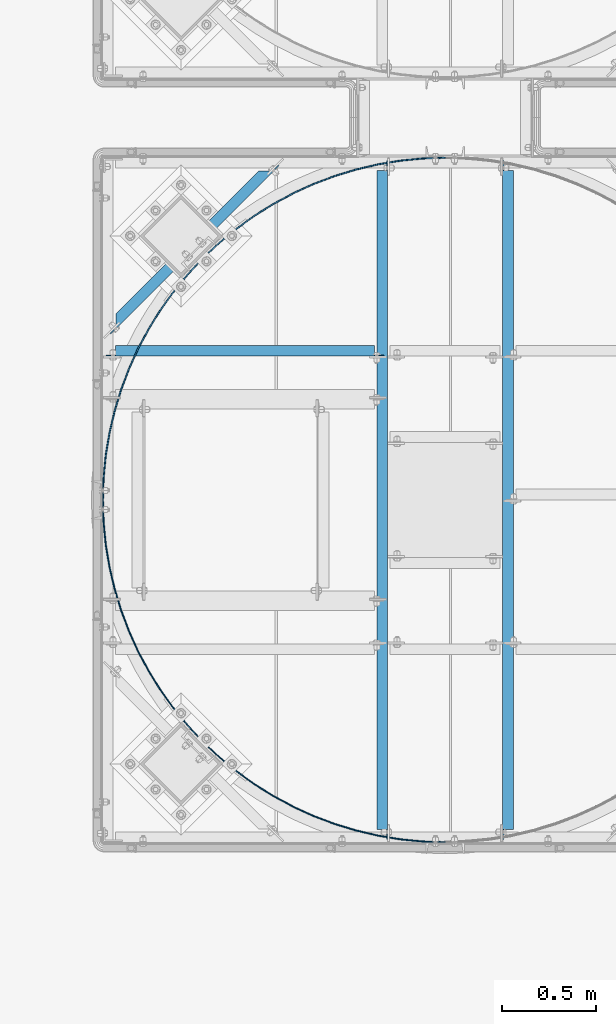
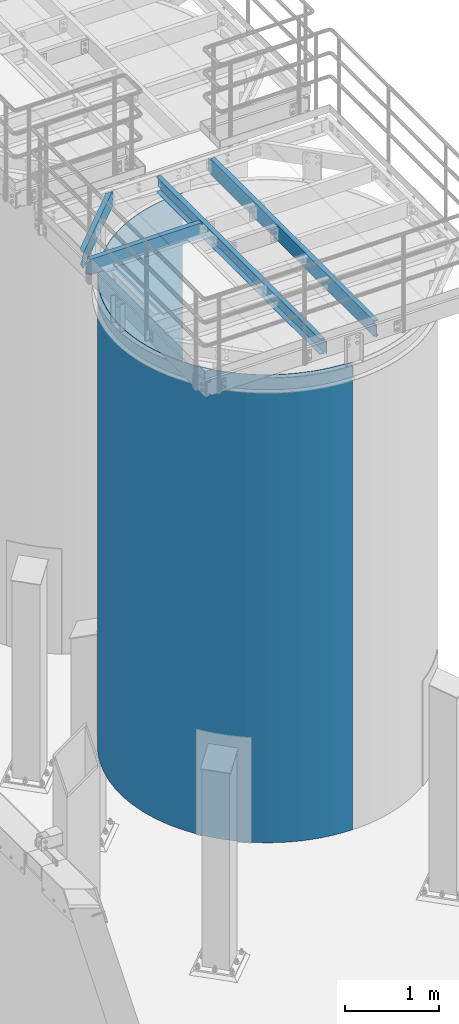
# One storey, part 921 of 1876: 5 beams, 5 elements without a shape of their own.
"""IFC2X3 building model written with IfcOpenShell, lengths in millimetres."""

from ifc_helpers import new_model, si_unit, frame, origin_with_axes, place, context, subcontext, project, spatial, faceted_brep, material, type_object, element, aggregate, save


model = new_model("IFC2X3")

# Units and contexts
model_context = context("Model", 3, precision=1e-05, world=origin_with_axes())
body_context = subcontext(model_context, "Body", "Model", "MODEL_VIEW")
ifc_project = project(units=[si_unit("LENGTHUNIT", "METRE", prefix="MILLI"), si_unit("AREAUNIT", "SQUARE_METRE"), si_unit("VOLUMEUNIT", "CUBIC_METRE"), si_unit("MASSUNIT", "GRAM", prefix="KILO"), si_unit("TIMEUNIT", "SECOND"), si_unit("PLANEANGLEUNIT", "RADIAN"), si_unit("SOLIDANGLEUNIT", "STERADIAN"), si_unit("THERMODYNAMICTEMPERATUREUNIT", "DEGREE_CELSIUS"), si_unit("LUMINOUSINTENSITYUNIT", "LUMEN")], contexts=[model_context])

# Site, building, storey
site_placement = place(None, origin_with_axes())
site = spatial("IfcSite", under=ifc_project, at=site_placement, CompositionType="ELEMENT")
building_placement = place(site_placement, origin_with_axes())
building = spatial("IfcBuilding", under=site, at=building_placement, Name="Undefined", CompositionType="ELEMENT")
storey_placement = place(building_placement, origin_with_axes())
storey = spatial("IfcBuildingStorey", under=building, at=storey_placement, Name="Undefined", CompositionType="ELEMENT", Elevation=0.0)

# Assembly, beam
assembly_1_placement = place(storey_placement, origin_with_axes())
assembly_1 = element("IfcElementAssembly", 1, at=assembly_1_placement, inside=storey, Name="BEAM", AssemblyPlace="NOTDEFINED", PredefinedType="RIGID_FRAME")
ifc_material = material(Name="STEEL/A36")
beam_type_1 = type_object("IfcBeamType", Name="C8X11.5", PredefinedType="NOTDEFINED")
beam_1_placement = place(assembly_1_placement, frame((3349.4630422288, -12731.5510638513, 7896.225), z_axis=(0.0, 0.0, -1.0), x_axis=(0.707106781186548, 0.707106781186547, 0.0)))
beam_1 = element("IfcBeam", 2, at=beam_1_placement, type_object=beam_type_1, material=ifc_material, Name="BEAM", ObjectType="C8X11.5", context=body_context, shape_type="Brep", body=[
    faceted_brep([(154.529650862243, -28.5750000000025, 101.6), (154.529650862243, -28.5750000000025, 96.8355949999996), (1223.93966372519, -28.5750000000044, 96.8355949999996), (1223.93966372519, -28.5750000000044, 101.6), (1281.0896637252, 28.5750000000053, 101.6), (1271.57228791927, 19.0576241940789, 88.8999998092668), (1281.0896637252, 28.5750000000053, 88.8999998092668), (97.3796508622331, 28.5750000000062, 101.6), (1299.05017569896, 28.5750000000053, -76.1999999999971), (1292.70017569896, 22.225000000004, -76.1999999999971), (1285.82698533033, 22.2250000000049, -77.1667299225846), (1292.17698533033, 28.5750000000062, -77.1667299225846), (1280.00017588969, 22.2250000000049, -79.9197438230631), (1286.35017588969, 28.5750000000062, -79.9197438230631), (1276.10682629423, 22.2250000000031, -84.0399202912167), (1282.45682629424, 28.5750000000044, -84.0399202912167), (1281.08966372656, 28.5750000000062, -88.8999998092622), (1271.57228792066, 19.0576241941089, -88.8999998092622), (1223.93966372655, -28.5750000000035, -96.8355949999996), (1223.93966372655, -28.5750000000035, -101.6), (1281.08966372656, 28.5750000000062, -101.6), (1274.88810387369, 22.225000000004, -88.3723149999996), (103.581210715046, 22.225000000004, -88.3723149999996), (106.897026668097, 19.0576241940926, -88.899999809265), (154.529650862193, -28.5750000000044, -96.8355949999996), (154.529650862193, -28.5750000000044, -101.6), (97.3796508621845, 28.5750000000044, -101.6), (97.3796508621845, 28.5750000000044, -88.899999809265), (102.362488294509, 22.225000000004, -84.0399202912195), (96.0124882945074, 28.5750000000062, -84.0399202912195), (98.4691386990489, 22.2250000000058, -79.9197438230658), (92.1191386990495, 28.5750000000044, -79.9197438230658), (92.6423292584141, 22.225000000004, -77.1667299225874), (86.2923292584137, 28.5750000000044, -77.1667299225874), (85.7691388897797, 22.225000000004, -76.1999999999998), (79.4191388897784, 28.5750000000062, -76.1999999999998), (59.1474759898592, 22.225000000004, -76.1999999999998), (59.1474759898588, 28.5750000000062, -76.1999999999998), (59.1474759898592, 22.225000000004, 76.1999999999998), (59.1474759898588, 28.5750000000062, 76.1999999999998), (85.7691388898302, 22.225000000004, 76.1999999999998), (79.4191388898289, 28.5750000000062, 76.1999999999998), (92.6423292584636, 22.225000000004, 77.1667299225874), (86.2923292584624, 28.5750000000062, 77.1667299225874), (98.4691386990994, 22.225000000004, 79.9197438230658), (92.119138699099, 28.5750000000062, 79.9197438230658), (102.362488294559, 22.225000000004, 84.0399202912195), (96.0124882945579, 28.5750000000062, 84.0399202912195), (106.897026668147, 19.0576241940926, 88.899999809265), (97.3796508622331, 28.5750000000062, 88.899999809265), (103.581210715098, 22.225000000004, 88.3723149999996), (1274.88810387234, 22.2250000000049, 88.3723149999996), (1276.10682629288, 22.225000000004, 84.0399202912213), (1282.45682629288, 28.5750000000044, 84.0399202912213), (1280.00017588834, 22.225000000004, 79.9197438230676), (1286.35017588834, 28.5750000000053, 79.9197438230676), (1285.82698532897, 22.225000000004, 77.1667299225892), (1292.17698532897, 28.5750000000053, 77.1667299225892), (1292.7001756976, 22.2250000000049, 76.2000000000016), (1299.0501756976, 28.5750000000053, 76.2000000000016), (1319.3218385947, 22.225000000004, 76.2000000000016), (1319.3218385947, 28.5750000000053, 76.2000000000016), (1319.3218385947, 28.5750000000053, -76.1999999999971), (1319.3218385947, 22.225000000004, -76.1999999999971)], [[[0, 1, 2, 3]], [[4, 3, 2, 5, 6]], [[7, 0, 3, 4]], [[8, 9, 10, 11]], [[11, 10, 12, 13]], [[13, 12, 14, 15]], [[16, 17, 18, 19, 20]], [[15, 14, 21, 17, 16]], [[22, 23, 24, 18, 17, 21]], [[24, 25, 19, 18]], [[25, 26, 20, 19]], [[24, 23, 27, 26, 25]], [[22, 28, 29, 27, 23]], [[30, 31, 29, 28]], [[32, 33, 31, 30]], [[34, 35, 33, 32]], [[35, 34, 36, 37]], [[37, 36, 38, 39]], [[40, 41, 39, 38]], [[42, 43, 41, 40]], [[44, 45, 43, 42]], [[46, 47, 45, 44]], [[48, 49, 47, 46, 50]], [[0, 7, 49, 48, 1]], [[2, 1, 48, 50, 51, 5]], [[6, 5, 51, 52, 53]], [[53, 52, 54, 55]], [[55, 54, 56, 57]], [[57, 56, 58, 59]], [[59, 58, 60, 61]], [[41, 43, 45, 47, 49, 7, 4, 6, 53, 55, 57, 59, 61, 62, 8, 11, 13, 15, 16, 20, 26, 27, 29, 31, 33, 35, 37, 39]], [[9, 8, 62, 63]], [[34, 32, 30, 28, 22, 21, 14, 12, 10, 9, 63, 60, 58, 56, 54, 52, 51, 50, 46, 44, 42, 40, 38, 36]], [[62, 61, 60, 63]]]),
])
aggregate(assembly_1, [beam_1])

assembly_2_placement = place(storey_placement, origin_with_axes())
assembly_2 = element("IfcElementAssembly", 3, at=assembly_2_placement, inside=storey, Name="BEAM", AssemblyPlace="NOTDEFINED", PredefinedType="RIGID_FRAME")
beam_2_placement = place(assembly_2_placement, frame((3365.50143150122, -12798.3894042969, 7896.225), z_axis=(0.0, 0.0, -1.0), x_axis=(1.0, 0.0, 0.0)))
beam_2 = element("IfcBeam", 4, at=beam_2_placement, type_object=beam_type_1, material=ifc_material, Name="BEAM", ObjectType="C8X11.5", context=body_context, shape_type="Brep", body=[
    faceted_brep([(19.0499999999993, 22.2250000000004, -76.2000000000007), (19.0499999999993, 28.5750000000007, -76.2000000000007), (57.1500001907361, 28.5750000000007, -76.2000000000007), (57.1500001907361, 22.2250000000004, -76.2000000000007), (62.0100797087816, 28.5750000000007, -77.1667299225883), (62.0100797087816, 22.2250000000004, -77.1667299225883), (66.1302561769353, 28.5750000000007, -79.9197438230667), (66.1302561769353, 22.2250000000004, -79.9197438230667), (68.8832700774137, 28.5750000000007, -84.0399202912204), (68.8832700774137, 22.2250000000004, -84.0399202912204), (69.8500000000013, 19.0576241940817, -88.8999998092659), (69.8500000000013, 28.5750000000007, -88.8999998092659), (69.8500000000013, 28.5750000000007, -101.6), (69.8500000000013, -28.5750000000007, -101.6), (69.8500000000013, -28.5750000000007, -96.8355949999996), (69.7450369653598, 22.2250000000004, -88.3723149999996), (1441.45, -28.5750000000007, -96.8355949999996), (1441.45, -28.5750000000007, -101.6), (1441.45, 28.5750000000007, -101.6), (1441.45, 28.5750000000007, -88.899999809264), (1441.45, 19.0576241940926, -88.899999809264), (69.8500000000013, -28.5750000000007, 101.6), (69.8500000000013, -28.5750000000007, 96.8355949999996), (1441.45, -28.5750000000007, 96.8355949999996), (1441.45, -28.5750000000007, 101.6), (1441.45, 19.0576241940817, 88.8999998092659), (1441.45, 28.5750000000007, 88.8999998092659), (1441.45, 28.5750000000007, 101.6), (69.8500000000013, 28.5750000000007, 101.6), (57.1500001907361, 22.2250000000004, 76.1999999999989), (57.1500001907361, 28.5750000000007, 76.1999999999989), (19.0499999999993, 28.5750000000007, 76.1999999999989), (19.0499999999993, 22.2250000000004, 76.1999999999989), (62.0100797087816, 22.2250000000004, 77.1667299225865), (62.0100797087816, 28.5750000000007, 77.1667299225865), (66.1302561769353, 22.2250000000004, 79.9197438230649), (66.1302561769353, 28.5750000000007, 79.9197438230649), (68.8832700774137, 22.2250000000004, 84.0399202912186), (68.8832700774137, 28.5750000000007, 84.0399202912186), (69.8500000000013, 19.0576241940926, 88.899999809264), (69.8500000000013, 28.5750000000007, 88.899999809264), (69.7450369653607, 22.2250000000004, 88.3723149999996), (1441.55496303464, 22.2250000000004, 88.3723149999996), (1442.41672992259, 22.2250000000004, 84.0399202912204), (1442.41672992259, 28.5750000000007, 84.0399202912204), (1445.16974382306, 22.2250000000004, 79.9197438230667), (1445.16974382306, 28.5750000000007, 79.9197438230667), (1449.28992029122, 22.2250000000004, 77.1667299225883), (1449.28992029122, 28.5750000000007, 77.1667299225883), (1454.14999980926, 22.2250000000004, 76.2000000000007), (1454.14999980926, 28.5750000000007, 76.2000000000007), (1492.25, 22.2250000000004, 76.2000000000007), (1492.25, 28.5750000000007, 76.2000000000007), (1492.25, 22.2250000000004, -76.1999999999989), (1492.25, 28.5750000000007, -76.1999999999989), (1454.14999980926, 22.2250000000004, -76.1999999999989), (1454.14999980926, 28.5750000000007, -76.1999999999989), (1449.28992029122, 22.2250000000004, -77.1667299225865), (1449.28992029122, 28.5750000000007, -77.1667299225865), (1445.16974382306, 22.2250000000004, -79.9197438230649), (1445.16974382306, 28.5750000000007, -79.9197438230649), (1442.41672992259, 22.2250000000004, -84.0399202912186), (1442.41672992259, 28.5750000000007, -84.0399202912186), (1441.55496303464, 22.2250000000004, -88.3723149999996)], [[[0, 1, 2, 3]], [[3, 2, 4, 5]], [[5, 4, 6, 7]], [[7, 6, 8, 9]], [[10, 11, 12, 13, 14]], [[15, 9, 8, 11, 10]], [[16, 17, 18, 19, 20]], [[21, 22, 23, 24]], [[24, 23, 25, 26, 27]], [[28, 21, 24, 27]], [[29, 30, 31, 32]], [[33, 34, 30, 29]], [[35, 36, 34, 33]], [[37, 38, 36, 35]], [[39, 40, 38, 37, 41]], [[21, 28, 40, 39, 22]], [[22, 39, 41, 42, 25, 23]], [[43, 44, 26, 25, 42]], [[45, 46, 44, 43]], [[47, 48, 46, 45]], [[49, 50, 48, 47]], [[51, 52, 50, 49]], [[52, 51, 53, 54]], [[53, 55, 56, 54]], [[57, 58, 56, 55]], [[59, 60, 58, 57]], [[61, 62, 60, 59]], [[63, 20, 19, 62, 61]], [[15, 10, 14, 16, 20, 63]], [[14, 13, 17, 16]], [[13, 12, 18, 17]], [[58, 60, 62, 19, 18, 12, 11, 8, 6, 4, 2, 1, 31, 30, 34, 36, 38, 40, 28, 27, 26, 44, 46, 48, 50, 52, 54, 56]], [[32, 31, 1, 0]], [[51, 49, 47, 45, 43, 42, 41, 37, 35, 33, 29, 32, 0, 3, 5, 7, 9, 15, 63, 61, 59, 57, 55, 53]]]),
])
aggregate(assembly_2, [beam_2])

assembly_3_placement = place(storey_placement, origin_with_axes())
assembly_3 = element("IfcElementAssembly", 5, at=assembly_3_placement, inside=storey, Name="BEAM", AssemblyPlace="NOTDEFINED", PredefinedType="RIGID_FRAME")
beam_3_placement = place(assembly_3_placement, frame((5514.97643150122, -15405.0644042969, 7896.225), z_axis=(0.0, 0.0, 1.0), x_axis=(0.0, 1.0, 0.0)))
beam_3 = element("IfcBeam", 6, at=beam_3_placement, type_object=beam_type_1, material=ifc_material, Name="BEAM", ObjectType="C8X11.5", context=body_context, shape_type="Brep", body=[
    faceted_brep([(19.0499999999993, 22.2250000000004, -76.2000000000007), (19.0499999999993, 28.5750000000007, -76.2000000000007), (57.1500001907361, 28.5750000000007, -76.2000000000007), (57.1500001907361, 22.2250000000004, -76.2000000000007), (62.0100797087816, 28.5750000000007, -77.1667299225883), (62.0100797087816, 22.2250000000004, -77.1667299225883), (66.1302561769353, 28.5750000000007, -79.9197438230667), (66.1302561769353, 22.2250000000004, -79.9197438230667), (68.8832700774137, 28.5750000000007, -84.0399202912204), (68.8832700774137, 22.2250000000004, -84.0399202912204), (69.8500000000013, 19.0576241940817, -88.8999998092659), (69.8500000000013, 28.5750000000007, -88.8999998092659), (69.8500000000013, 28.5750000000007, -101.6), (69.8500000000013, -28.5750000000007, -101.6), (69.8500000000013, -28.5750000000007, -96.8355949999996), (69.7450369653598, 22.2250000000004, -88.3723149999996), (3562.3499511731, -28.5749999999998, -96.8355949999996), (3562.3499511731, -28.5749999999998, -101.6), (3562.3499511731, 28.5749999999998, -101.6), (3562.3499511731, 28.5749999999998, -88.899999809264), (3562.3499511731, 19.0576241940935, -88.899999809264), (69.8500000000013, -28.5750000000007, 101.6), (69.8500000000013, -28.5750000000007, 96.8355949999996), (3562.3499511731, -28.5749999999998, 96.8355949999996), (3562.3499511731, -28.5749999999998, 101.6), (3562.3499511731, 19.0576241940826, 88.8999998092659), (3562.3499511731, 28.5749999999998, 88.8999998092659), (3562.3499511731, 28.5749999999998, 101.6), (69.8500000000013, 28.5750000000007, 101.6), (57.1500001907361, 22.2250000000004, 76.1999999999989), (57.1500001907361, 28.5750000000007, 76.1999999999989), (19.0499999999993, 28.5750000000007, 76.1999999999989), (19.0499999999993, 22.2250000000004, 76.1999999999989), (62.0100797087816, 22.2250000000004, 77.1667299225865), (62.0100797087816, 28.5750000000007, 77.1667299225865), (66.1302561769353, 22.2250000000004, 79.9197438230649), (66.1302561769353, 28.5750000000007, 79.9197438230649), (68.8832700774137, 22.2250000000004, 84.0399202912186), (68.8832700774137, 28.5750000000007, 84.0399202912186), (69.8500000000013, 19.0576241940926, 88.899999809264), (69.8500000000013, 28.5750000000007, 88.899999809264), (69.7450369653607, 22.2250000000004, 88.3723149999996), (3562.45491420775, 22.2250000000004, 88.3723149999996), (3563.31668109569, 22.2250000000004, 84.0399202912204), (3563.31668109569, 28.5749999999998, 84.0399202912204), (3566.06969499617, 22.2250000000004, 79.9197438230667), (3566.06969499617, 28.5749999999998, 79.9197438230667), (3570.18987146432, 22.2250000000004, 77.1667299225883), (3570.18987146432, 28.5749999999998, 77.1667299225883), (3575.04995098237, 22.2250000000004, 76.2000000000007), (3575.04995098237, 28.5749999999998, 76.2000000000007), (3613.1499511731, 22.2250000000004, 76.2000000000007), (3613.1499511731, 28.5749999999998, 76.2000000000007), (3613.1499511731, 22.2250000000004, -76.1999999999989), (3613.1499511731, 28.5749999999998, -76.1999999999989), (3575.04995098237, 22.2250000000004, -76.1999999999989), (3575.04995098237, 28.5749999999998, -76.1999999999989), (3570.18987146432, 22.2250000000004, -77.1667299225865), (3570.18987146432, 28.5749999999998, -77.1667299225865), (3566.06969499617, 22.2250000000004, -79.9197438230649), (3566.06969499617, 28.5749999999998, -79.9197438230649), (3563.31668109569, 22.2250000000004, -84.0399202912186), (3563.31668109569, 28.5749999999998, -84.0399202912186), (3562.45491420774, 22.2250000000004, -88.3723149999996)], [[[0, 1, 2, 3]], [[3, 2, 4, 5]], [[5, 4, 6, 7]], [[7, 6, 8, 9]], [[10, 11, 12, 13, 14]], [[15, 9, 8, 11, 10]], [[16, 17, 18, 19, 20]], [[21, 22, 23, 24]], [[24, 23, 25, 26, 27]], [[28, 21, 24, 27]], [[29, 30, 31, 32]], [[33, 34, 30, 29]], [[35, 36, 34, 33]], [[37, 38, 36, 35]], [[39, 40, 38, 37, 41]], [[21, 28, 40, 39, 22]], [[22, 39, 41, 42, 25, 23]], [[43, 44, 26, 25, 42]], [[45, 46, 44, 43]], [[47, 48, 46, 45]], [[49, 50, 48, 47]], [[51, 52, 50, 49]], [[52, 51, 53, 54]], [[53, 55, 56, 54]], [[57, 58, 56, 55]], [[59, 60, 58, 57]], [[61, 62, 60, 59]], [[63, 20, 19, 62, 61]], [[15, 10, 14, 16, 20, 63]], [[14, 13, 17, 16]], [[13, 12, 18, 17]], [[58, 60, 62, 19, 18, 12, 11, 8, 6, 4, 2, 1, 31, 30, 34, 36, 38, 40, 28, 27, 26, 44, 46, 48, 50, 52, 54, 56]], [[32, 31, 1, 0]], [[51, 49, 47, 45, 43, 42, 41, 37, 35, 33, 29, 32, 0, 3, 5, 7, 9, 15, 63, 61, 59, 57, 55, 53]]]),
])
aggregate(assembly_3, [beam_3])

assembly_4_placement = place(storey_placement, origin_with_axes())
assembly_4 = element("IfcElementAssembly", 7, at=assembly_4_placement, inside=storey, Name="BEAM", AssemblyPlace="NOTDEFINED", PredefinedType="RIGID_FRAME")
beam_4_placement = place(assembly_4_placement, frame((4848.22643150122, -15405.0644042969, 7896.225), z_axis=(0.0, 0.0, -1.0), x_axis=(0.0, 1.0, 0.0)))
beam_4 = element("IfcBeam", 8, at=beam_4_placement, type_object=beam_type_1, material=ifc_material, Name="BEAM", ObjectType="C8X11.5", context=body_context, shape_type="Brep", body=[
    faceted_brep([(19.0499999999993, 22.2250000000004, -76.2000000000007), (19.0499999999993, 28.5750000000007, -76.2000000000007), (57.1500001907361, 28.5750000000007, -76.2000000000007), (57.1500001907361, 22.2250000000004, -76.2000000000007), (62.0100797087816, 28.5750000000007, -77.1667299225883), (62.0100797087816, 22.2250000000004, -77.1667299225883), (66.1302561769353, 28.5750000000007, -79.9197438230667), (66.1302561769353, 22.2250000000004, -79.9197438230667), (68.8832700774137, 28.5750000000007, -84.0399202912204), (68.8832700774137, 22.2250000000004, -84.0399202912204), (69.8500000000013, 19.0576241940817, -88.8999998092659), (69.8500000000013, 28.5750000000007, -88.8999998092659), (69.8500000000013, 28.5750000000007, -101.6), (69.8500000000013, -28.5750000000007, -101.6), (69.8500000000013, -28.5750000000007, -96.8355949999996), (69.7450369653598, 22.2250000000004, -88.3723149999996), (3562.3499511731, -28.5749999999998, -96.8355949999996), (3562.3499511731, -28.5749999999998, -101.6), (3562.3499511731, 28.5749999999998, -101.6), (3562.3499511731, 28.5749999999998, -88.899999809264), (3562.3499511731, 19.0576241940935, -88.899999809264), (69.8500000000013, -28.5750000000007, 101.6), (69.8500000000013, -28.5750000000007, 96.8355949999996), (3562.3499511731, -28.5749999999998, 96.8355949999996), (3562.3499511731, -28.5749999999998, 101.6), (3562.3499511731, 19.0576241940826, 88.8999998092659), (3562.3499511731, 28.5749999999998, 88.8999998092659), (3562.3499511731, 28.5749999999998, 101.6), (69.8500000000013, 28.5750000000007, 101.6), (57.1500001907361, 22.2250000000004, 76.1999999999989), (57.1500001907361, 28.5750000000007, 76.1999999999989), (19.0499999999993, 28.5750000000007, 76.1999999999989), (19.0499999999993, 22.2250000000004, 76.1999999999989), (62.0100797087816, 22.2250000000004, 77.1667299225865), (62.0100797087816, 28.5750000000007, 77.1667299225865), (66.1302561769353, 22.2250000000004, 79.9197438230649), (66.1302561769353, 28.5750000000007, 79.9197438230649), (68.8832700774137, 22.2250000000004, 84.0399202912186), (68.8832700774137, 28.5750000000007, 84.0399202912186), (69.8500000000013, 19.0576241940926, 88.899999809264), (69.8500000000013, 28.5750000000007, 88.899999809264), (69.7450369653607, 22.2250000000004, 88.3723149999996), (3562.45491420775, 22.2250000000004, 88.3723149999996), (3563.31668109569, 22.2250000000004, 84.0399202912204), (3563.31668109569, 28.5749999999998, 84.0399202912204), (3566.06969499617, 22.2250000000004, 79.9197438230667), (3566.06969499617, 28.5749999999998, 79.9197438230667), (3570.18987146432, 22.2250000000004, 77.1667299225883), (3570.18987146432, 28.5749999999998, 77.1667299225883), (3575.04995098237, 22.2250000000004, 76.2000000000007), (3575.04995098237, 28.5749999999998, 76.2000000000007), (3613.1499511731, 22.2250000000004, 76.2000000000007), (3613.1499511731, 28.5749999999998, 76.2000000000007), (3613.1499511731, 22.2250000000004, -76.1999999999989), (3613.1499511731, 28.5749999999998, -76.1999999999989), (3575.04995098237, 22.2250000000004, -76.1999999999989), (3575.04995098237, 28.5749999999998, -76.1999999999989), (3570.18987146432, 22.2250000000004, -77.1667299225865), (3570.18987146432, 28.5749999999998, -77.1667299225865), (3566.06969499617, 22.2250000000004, -79.9197438230649), (3566.06969499617, 28.5749999999998, -79.9197438230649), (3563.31668109569, 22.2250000000004, -84.0399202912186), (3563.31668109569, 28.5749999999998, -84.0399202912186), (3562.45491420774, 22.2250000000004, -88.3723149999996)], [[[0, 1, 2, 3]], [[3, 2, 4, 5]], [[5, 4, 6, 7]], [[7, 6, 8, 9]], [[10, 11, 12, 13, 14]], [[15, 9, 8, 11, 10]], [[16, 17, 18, 19, 20]], [[21, 22, 23, 24]], [[24, 23, 25, 26, 27]], [[28, 21, 24, 27]], [[29, 30, 31, 32]], [[33, 34, 30, 29]], [[35, 36, 34, 33]], [[37, 38, 36, 35]], [[39, 40, 38, 37, 41]], [[21, 28, 40, 39, 22]], [[22, 39, 41, 42, 25, 23]], [[43, 44, 26, 25, 42]], [[45, 46, 44, 43]], [[47, 48, 46, 45]], [[49, 50, 48, 47]], [[51, 52, 50, 49]], [[52, 51, 53, 54]], [[53, 55, 56, 54]], [[57, 58, 56, 55]], [[59, 60, 58, 57]], [[61, 62, 60, 59]], [[63, 20, 19, 62, 61]], [[15, 10, 14, 16, 20, 63]], [[14, 13, 17, 16]], [[13, 12, 18, 17]], [[58, 60, 62, 19, 18, 12, 11, 8, 6, 4, 2, 1, 31, 30, 34, 36, 38, 40, 28, 27, 26, 44, 46, 48, 50, 52, 54, 56]], [[32, 31, 1, 0]], [[51, 49, 47, 45, 43, 42, 41, 37, 35, 33, 29, 32, 0, 3, 5, 7, 9, 15, 63, 61, 59, 57, 55, 53]]]),
])
aggregate(assembly_4, [beam_4])

assembly_5_placement = place(storey_placement, origin_with_axes())
assembly_5 = element("IfcElementAssembly", 9, at=assembly_5_placement, inside=storey, Name="PLATE", AssemblyPlace="NOTDEFINED", PredefinedType="RIGID_FRAME")
beam_type_2 = type_object("IfcBeamType", PredefinedType="NOTDEFINED")
beam_5_placement = place(assembly_5_placement, frame((5183.84647111802, -15402.8193402666, 4572.0), z_axis=(0.0, 0.0, 1.0), x_axis=(-0.707106781186548, 0.707106781186547, 0.0)))
beam_5 = element("IfcBeam", 10, at=beam_5_placement, type_object=beam_type_2, material=ifc_material, Name="PLATE", context=body_context, shape_type="Brep", body=[
    faceted_brep([(4.49012806053543, -1.31512806053706, -3048.0), (4.49012806053543, -1.31512806053706, 3048.0), (0.0, 3.17500000000018, 3048.0), (0.0, 3.17500000000018, -3048.0), (86.7386893436651, 84.4146479575566, 3048.0), (86.7386893436651, 84.4146479575566, -3048.0), (90.9255352695491, 79.6404651800631, -3048.0), (90.9255352695491, 79.6404651800631, 3048.0), (182.470626763443, 154.769580173522, -3048.0), (182.470626763443, 154.769580173522, 3048.0), (178.604991689237, 159.807373884371, 3048.0), (178.604991689237, 159.807373884371, -3048.0), (278.733392406179, 223.750502515405, -3048.0), (278.733392406179, 223.750502515405, 3048.0), (275.205521426506, 229.030334553528, 3048.0), (275.205521426506, 229.030334553528, -3048.0), (379.301620256749, 286.287845306104, -3048.0), (379.301620256749, 286.287845306104, 3048.0), (376.126620256751, 291.787106620136, 3048.0), (376.126620256751, 291.787106620136, -3048.0), (483.744661723982, 342.113814042878, -3048.0), (483.744661723982, 342.113814042878, 3048.0), (480.936128541092, 347.808955951613, 3048.0), (480.936128541092, 347.808955951613, -3048.0), (591.615275669927, 390.989353357043, -3048.0), (591.615275669927, 390.989353357043, 3048.0), (589.185235874411, 396.855988388491, 3048.0), (589.185235874411, 396.855988388491, -3048.0), (702.451543565072, 432.705170685742, -3048.0), (702.451543565072, 432.705170685742, 3048.0), (700.410402960399, 438.718177008037, 3048.0), (700.410402960399, 438.718177008037, -3048.0), (815.778847494395, 467.082632494846, -3048.0), (815.778847494395, 467.082632494846, 3048.0), (814.135346557994, 473.216261491782, 3048.0), (814.135346557994, 473.216261491782, -3048.0), (931.111902544148, 493.974529215167, -3048.0), (931.111902544148, 493.974529215167, 3048.0), (929.873078999346, 500.202515745727, 3048.0), (929.873078999346, 500.202515745727, -3048.0), (1047.95683486635, 513.265705616425, -3048.0), (1047.95683486635, 513.265705616425, 3048.0), (1047.12799354576, 519.56138048615, 3048.0), (1047.12799354576, 519.56138048615, -3048.0), (1165.81329652245, 524.873553919638, -3048.0), (1165.81329652245, 524.873553919638, 3048.0), (1165.39798665184, 531.209958082205, 3048.0), (1165.39798665184, 531.209958082205, -3048.0), (1284.17660804998, 528.748367536302, -3048.0), (1284.17660804998, 528.748367536302, 3048.0), (1284.17660804998, 535.098367536303, 3048.0), (1284.17660804998, 535.098367536303, -3048.0), (1402.5399195775, 524.873553919638, -3048.0), (1402.5399195775, 524.873553919638, 3048.0), (1402.95522944811, 531.209958082204, 3048.0), (1402.95522944811, 531.209958082204, -3048.0), (1520.3963812336, 513.265705616425, -3048.0), (1520.3963812336, 513.265705616425, 3048.0), (1521.2252225542, 519.56138048615, 3048.0), (1521.2252225542, 519.56138048615, -3048.0), (1637.24131355581, 493.974529215165, -3048.0), (1637.24131355581, 493.974529215165, 3048.0), (1638.48013710061, 500.202515745727, 3048.0), (1638.48013710061, 500.202515745727, -3048.0), (1752.57436860556, 467.082632494848, -3048.0), (1752.57436860556, 467.082632494848, 3048.0), (1754.21786954196, 473.216261491783, 3048.0), (1754.21786954196, 473.216261491783, -3048.0), (1865.90167253488, 432.705170685741, -3048.0), (1865.90167253488, 432.705170685741, 3048.0), (1867.94281313955, 438.718177008038, 3048.0), (1867.94281313955, 438.718177008038, -3048.0), (1976.73794043002, 390.989353357042, -3048.0), (1976.73794043002, 390.989353357042, 3048.0), (1979.16798022554, 396.855988388491, 3048.0), (1979.16798022554, 396.855988388491, -3048.0), (2084.60855437597, 342.113814042878, -3048.0), (2084.60855437597, 342.113814042878, 3048.0), (2087.41708755886, 347.808955951613, 3048.0), (2087.41708755886, 347.808955951613, -3048.0), (2189.0515958432, 286.287845306103, -3048.0), (2189.0515958432, 286.287845306103, 3048.0), (2192.2265958432, 291.787106620135, 3048.0), (2192.2265958432, 291.787106620135, -3048.0), (2289.61982369377, 223.750502515403, -3048.0), (2289.61982369377, 223.750502515403, 3048.0), (2293.14769467345, 229.030334553528, 3048.0), (2293.14769467345, 229.030334553528, -3048.0), (2385.88258933651, 154.76958017352, -3048.0), (2385.88258933651, 154.76958017352, 3048.0), (2389.74822441072, 159.807373884371, 3048.0), (2389.74822441072, 159.807373884371, -3048.0), (2477.4276808304, 79.6404651800613, -3048.0), (2477.4276808304, 79.6404651800613, 3048.0), (2481.61452675629, 84.4146479575547, 3048.0), (2481.61452675629, 84.4146479575547, -3048.0), (2563.86308803942, -1.31512806053706, -3048.0), (2563.86308803942, -1.31512806053706, 3048.0), (2568.35321609995, 3.17499999999927, 3048.0), (2568.35321609995, 3.17500000000018, -3048.0), (2649.59286405754, -83.5636893436485, 3048.0), (2649.59286405754, -83.5636893436485, -3048.0), (2724.98558998438, -175.429991689211, -3048.0), (2794.20855065357, -272.03052142647, -3048.0), (2856.9653227202, -372.951620256707, -3048.0), (2912.9871720517, -477.761128541047, -3048.0), (2962.03420448861, -586.010235874364, -3048.0), (3003.89639310817, -697.235402960353, -3048.0), (3038.39447759194, -810.960346557953, -3048.0), (3065.3807318459, -926.69807899931, -3048.0), (3084.73959658634, -1043.95299354573, -3048.0), (3096.3881741824, -1162.22298665182, -3048.0), (3100.27658363651, -1281.00160804996, -3048.0), (3096.38817418242, -1399.78022944811, -3048.0), (3084.73959658637, -1518.0502225542, -3048.0), (3065.38073184595, -1635.30513710062, -3048.0), (3038.394477592, -1751.04286954198, -3048.0), (3003.89639310825, -1864.76781313959, -3048.0), (2962.0342044887, -1975.99298022558, -3048.0), (2912.98717205181, -2084.2420875589, -3048.0), (2856.96532272033, -2189.05159584325, -3048.0), (2794.20855065371, -2289.9726946735, -3048.0), (2724.98558998454, -2386.57322441077, -3048.0), (2649.5928640577, -2478.43952675634, -3048.0), (2568.35321610013, -2565.1782161, -3048.0), (2563.86308803959, -2560.68808803946, -3048.0), (2644.81868128021, -2474.25268083045, -3048.0), (2719.94779627369, -2382.70758933656, -3048.0), (2788.92871861559, -2286.44482369382, -3048.0), (2851.46606140629, -2185.87659584325, -3048.0), (2907.29203014308, -2081.43355437601, -3048.0), (2956.16756945725, -1973.56294043006, -3048.0), (2997.88338678596, -1862.72667253491, -3048.0), (3032.26084859507, -1749.39936860558, -3048.0), (3059.15274531539, -1634.06631355582, -3048.0), (3078.44392171664, -1517.2213812336, -3048.0), (3090.05177001985, -1399.3649195775, -3048.0), (3093.92658363651, -1281.00160804996, -3048.0), (3090.05177001984, -1162.63829652243, -3048.0), (3078.44392171661, -1044.78183486633, -3048.0), (3059.15274531534, -927.936902544113, -3048.0), (3032.260848595, -812.603847494355, -3048.0), (2997.88338678588, -699.276543565029, -3048.0), (2956.16756945716, -588.440275669883, -3048.0), (2907.29203014297, -480.569661723938, -3048.0), (2851.46606140617, -376.126620256709, -3048.0), (2788.92871861544, -275.558392406144, -3048.0), (2719.94779627353, -179.295626763415, -3048.0), (2644.81868128004, -87.7505352695343, -3048.0), (2644.81868128004, -87.7505352695343, 3048.0), (2719.94779627353, -179.295626763415, 3048.0), (2788.92871861544, -275.558392406144, 3048.0), (2851.46606140617, -376.126620256709, 3048.0), (2907.29203014297, -480.569661723938, 3048.0), (2956.16756945716, -588.440275669883, 3048.0), (2997.88338678588, -699.276543565029, 3048.0), (3032.260848595, -812.603847494355, 3048.0), (3059.15274531534, -927.936902544113, 3048.0), (3078.44392171661, -1044.78183486633, 3048.0), (3090.05177001984, -1162.63829652243, 3048.0), (3093.92658363651, -1281.00160804996, 3048.0), (3090.05177001985, -1399.3649195775, 3048.0), (3078.44392171664, -1517.2213812336, 3048.0), (3059.15274531539, -1634.06631355582, 3048.0), (3032.26084859507, -1749.39936860558, 3048.0), (2997.88338678596, -1862.72667253491, 3048.0), (2956.16756945725, -1973.56294043006, 3048.0), (2907.29203014308, -2081.43355437601, 3048.0), (2851.46606140629, -2185.87659584325, 3048.0), (2788.92871861559, -2286.44482369382, 3048.0), (2719.94779627369, -2382.70758933656, 3048.0), (2644.81868128021, -2474.25268083045, 3048.0), (2563.86308803959, -2560.68808803946, 3048.0), (2568.35321610013, -2565.1782161, 3048.0), (2649.5928640577, -2478.43952675634, 3048.0), (2724.98558998454, -2386.57322441077, 3048.0), (2794.20855065371, -2289.9726946735, 3048.0), (2856.96532272033, -2189.05159584325, 3048.0), (2912.98717205181, -2084.2420875589, 3048.0), (2962.0342044887, -1975.99298022558, 3048.0), (3003.89639310825, -1864.76781313959, 3048.0), (3038.394477592, -1751.04286954198, 3048.0), (3065.38073184595, -1635.30513710062, 3048.0), (3084.73959658637, -1518.0502225542, 3048.0), (3096.38817418242, -1399.78022944811, 3048.0), (3100.27658363651, -1281.00160804996, 3048.0), (3096.3881741824, -1162.22298665182, 3048.0), (3084.73959658634, -1043.95299354573, 3048.0), (3065.3807318459, -926.69807899931, 3048.0), (3038.39447759194, -810.960346557953, 3048.0), (3003.89639310817, -697.235402960353, 3048.0), (2962.03420448861, -586.010235874364, 3048.0), (2912.9871720517, -477.761128541047, 3048.0), (2856.9653227202, -372.951620256708, 3048.0), (2794.20855065357, -272.030521426471, 3048.0), (2724.98558998438, -175.429991689211, 3048.0)], [[[0, 1, 2, 3]], [[3, 2, 4, 5]], [[1, 0, 6, 7]], [[6, 8, 9, 7]], [[4, 10, 11, 5]], [[8, 12, 13, 9]], [[10, 14, 15, 11]], [[12, 16, 17, 13]], [[14, 18, 19, 15]], [[16, 20, 21, 17]], [[18, 22, 23, 19]], [[20, 24, 25, 21]], [[22, 26, 27, 23]], [[24, 28, 29, 25]], [[26, 30, 31, 27]], [[28, 32, 33, 29]], [[30, 34, 35, 31]], [[32, 36, 37, 33]], [[34, 38, 39, 35]], [[36, 40, 41, 37]], [[38, 42, 43, 39]], [[40, 44, 45, 41]], [[42, 46, 47, 43]], [[44, 48, 49, 45]], [[46, 50, 51, 47]], [[48, 52, 53, 49]], [[50, 54, 55, 51]], [[52, 56, 57, 53]], [[54, 58, 59, 55]], [[56, 60, 61, 57]], [[58, 62, 63, 59]], [[60, 64, 65, 61]], [[62, 66, 67, 63]], [[64, 68, 69, 65]], [[66, 70, 71, 67]], [[68, 72, 73, 69]], [[70, 74, 75, 71]], [[72, 76, 77, 73]], [[74, 78, 79, 75]], [[76, 80, 81, 77]], [[78, 82, 83, 79]], [[80, 84, 85, 81]], [[82, 86, 87, 83]], [[84, 88, 89, 85]], [[86, 90, 91, 87]], [[88, 92, 93, 89]], [[90, 94, 95, 91]], [[92, 96, 97, 93]], [[94, 98, 99, 95]], [[99, 98, 100, 101]], [[102, 103, 104, 105, 106, 107, 108, 109, 110, 111, 112, 113, 114, 115, 116, 117, 118, 119, 120, 121, 122, 123, 124, 125, 126, 127, 128, 129, 130, 131, 132, 133, 134, 135, 136, 137, 138, 139, 140, 141, 142, 143, 144, 145, 146, 147, 148, 96, 92, 88, 84, 80, 76, 72, 68, 64, 60, 56, 52, 48, 44, 40, 36, 32, 28, 24, 20, 16, 12, 8, 6, 0, 3, 5, 11, 15, 19, 23, 27, 31, 35, 39, 43, 47, 51, 55, 59, 63, 67, 71, 75, 79, 83, 87, 91, 95, 99, 101]], [[97, 96, 148, 149]], [[150, 151, 152, 153, 154, 155, 156, 157, 158, 159, 160, 161, 162, 163, 164, 165, 166, 167, 168, 169, 170, 171, 172, 173, 174, 175, 176, 177, 178, 179, 180, 181, 182, 183, 184, 185, 186, 187, 188, 189, 190, 191, 192, 193, 194, 195, 100, 98, 94, 90, 86, 82, 78, 74, 70, 66, 62, 58, 54, 50, 46, 42, 38, 34, 30, 26, 22, 18, 14, 10, 4, 2, 1, 7, 9, 13, 17, 21, 25, 29, 33, 37, 41, 45, 49, 53, 57, 61, 65, 69, 73, 77, 81, 85, 89, 93, 97, 149]], [[148, 147, 150, 149]], [[100, 195, 102, 101]], [[147, 146, 151, 150]], [[195, 194, 103, 102]], [[146, 145, 152, 151]], [[194, 193, 104, 103]], [[145, 144, 153, 152]], [[193, 192, 105, 104]], [[144, 143, 154, 153]], [[192, 191, 106, 105]], [[143, 142, 155, 154]], [[191, 190, 107, 106]], [[142, 141, 156, 155]], [[190, 189, 108, 107]], [[141, 140, 157, 156]], [[189, 188, 109, 108]], [[140, 139, 158, 157]], [[188, 187, 110, 109]], [[139, 138, 159, 158]], [[187, 186, 111, 110]], [[138, 137, 160, 159]], [[186, 185, 112, 111]], [[137, 136, 161, 160]], [[185, 184, 113, 112]], [[136, 135, 162, 161]], [[184, 183, 114, 113]], [[135, 134, 163, 162]], [[183, 182, 115, 114]], [[134, 133, 164, 163]], [[182, 181, 116, 115]], [[133, 132, 165, 164]], [[181, 180, 117, 116]], [[132, 131, 166, 165]], [[180, 179, 118, 117]], [[131, 130, 167, 166]], [[179, 178, 119, 118]], [[130, 129, 168, 167]], [[178, 177, 120, 119]], [[129, 128, 169, 168]], [[177, 176, 121, 120]], [[128, 127, 170, 169]], [[176, 175, 122, 121]], [[127, 126, 171, 170]], [[175, 174, 123, 122]], [[172, 125, 124, 173]], [[126, 125, 172, 171]], [[174, 173, 124, 123]]]),
])
aggregate(assembly_5, [beam_5])

save(model, "model.ifc")
